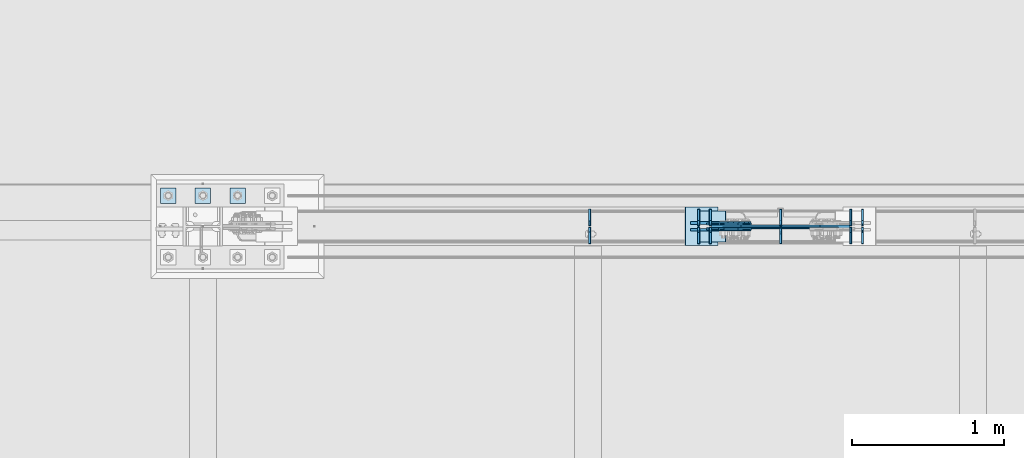
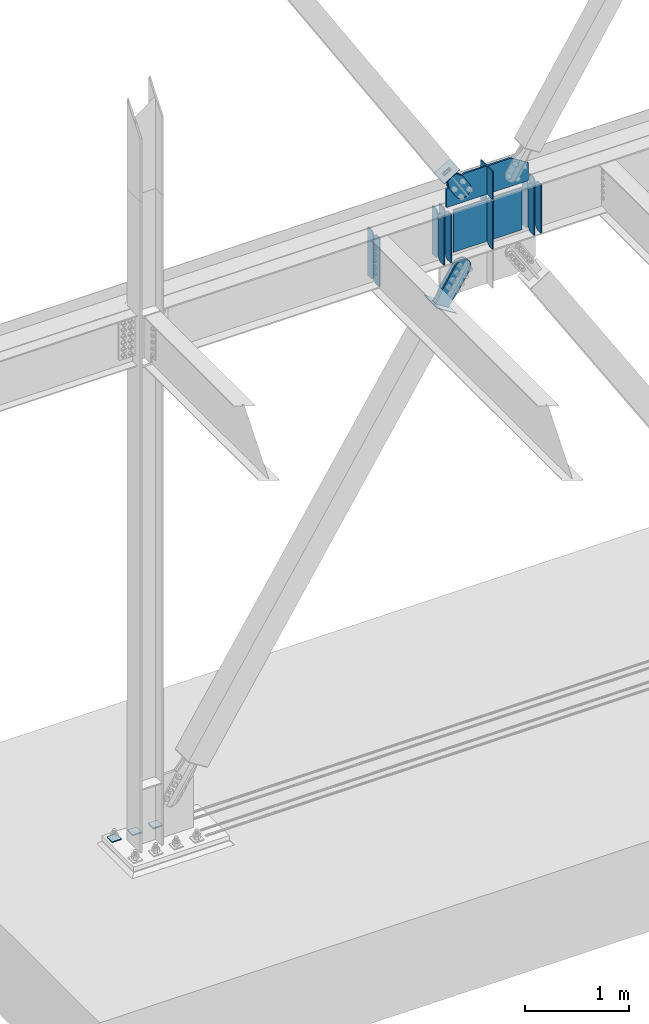
# One storey, part 3521 of 3843: 25 plates, 8 elements without a shape of their own.
"""IFC2X3 building model written with IfcOpenShell, lengths in millimetres."""

from ifc_helpers import new_model, si_unit, frame, origin_with_axes, place, context, subcontext, project, spatial, faceted_brep, material, type_object, element, aggregate, save


model = new_model("IFC2X3")

# Units and contexts
model_context = context("Model", 3, precision=1e-05, world=origin_with_axes())
body_context = subcontext(model_context, "Body", "Model", "MODEL_VIEW")
ifc_project = project(units=[si_unit("LENGTHUNIT", "METRE", prefix="MILLI"), si_unit("AREAUNIT", "SQUARE_METRE"), si_unit("VOLUMEUNIT", "CUBIC_METRE"), si_unit("MASSUNIT", "GRAM", prefix="KILO"), si_unit("TIMEUNIT", "SECOND"), si_unit("PLANEANGLEUNIT", "RADIAN"), si_unit("SOLIDANGLEUNIT", "STERADIAN"), si_unit("THERMODYNAMICTEMPERATUREUNIT", "DEGREE_CELSIUS"), si_unit("LUMINOUSINTENSITYUNIT", "LUMEN")], contexts=[model_context])

# Site, building, storey
site_placement = place(None, origin_with_axes())
site = spatial("IfcSite", under=ifc_project, at=site_placement, CompositionType="ELEMENT")
building_placement = place(site_placement, origin_with_axes())
building = spatial("IfcBuilding", under=site, at=building_placement, Name="Undefined", CompositionType="ELEMENT")
storey_placement = place(building_placement, origin_with_axes())
storey = spatial("IfcBuildingStorey", under=building, at=storey_placement, Name="Undefined", CompositionType="ELEMENT", Elevation=0.0)

# Assembly, plates
assembly_1_placement = place(storey_placement, origin_with_axes())
assembly_1 = element("IfcElementAssembly", 1, at=assembly_1_placement, inside=storey, Name="BEAM", AssemblyPlace="NOTDEFINED", PredefinedType="RIGID_FRAME")
ifc_material_1 = material(Name="STEEL/A572-50")
plate_type_1 = type_object("IfcPlateType", PredefinedType="NOTDEFINED")
plate_1_placement = place(assembly_1_placement, frame((25411.1125000954, 104564.65625, 35848.925), z_axis=(0.0, 0.0, 1.0), x_axis=(0.0, 1.0, 0.0)))
plate_1 = element("IfcPlate", 2, at=plate_1_placement, type_object=plate_type_1, material=ifc_material_1, Name="PLATE", context=body_context, shape_type="Brep", body=[
    faceted_brep([(0.0, -6.35000000000582, 31.75), (0.0, -6.34999999999854, 539.75), (0.0, 6.34999999999854, 539.75), (0.0, 6.35000000000582, 31.75), (31.75, -6.34999999999854, 571.5), (31.75, 6.34999999999854, 571.5), (108.743750000009, -6.34999999999854, 571.5), (108.743750000009, 6.34999999999854, 571.5), (108.743750000009, -6.34999999999854, 0.0), (108.743750000009, 6.34999999999854, 0.0), (31.75, -6.35000000000582, 0.0), (31.75, 6.35000000000582, 0.0)], [[[0, 1, 2, 3]], [[1, 4, 5, 2]], [[4, 6, 7, 5]], [[6, 8, 9, 7]], [[8, 10, 11, 9]], [[10, 0, 3, 11]], [[5, 7, 9, 11, 3, 2]], [[10, 8, 6, 4, 1, 0]]]),
])
plate_type_2 = type_object("IfcPlateType", PredefinedType="NOTDEFINED")
plate_2_placement = place(assembly_1_placement, frame((25411.1125000954, 104553.54375, 35848.925), z_axis=(0.0, 0.0, 1.0), x_axis=(0.0, -1.0, 0.0)))
plate_2 = element("IfcPlate", 3, at=plate_2_placement, type_object=plate_type_2, material=ifc_material_1, Name="PLATE", context=body_context, shape_type="Brep", body=[
    faceted_brep([(0.0, -6.35000000000582, 31.75), (0.0, -6.34999999999854, 539.75), (0.0, 6.34999999999854, 539.75), (0.0, 6.35000000000582, 31.75), (31.75, -6.34999999999854, 571.5), (31.75, 6.34999999999854, 571.5), (107.950000000012, -6.34999999999854, 571.5), (107.950000000012, 6.34999999999854, 571.5), (107.950000000012, -6.34999999999854, 0.0), (107.950000000012, 6.34999999999854, 0.0), (31.75, -6.35000000000582, 0.0), (31.75, 6.35000000000582, 0.0)], [[[0, 1, 2, 3]], [[1, 4, 5, 2]], [[4, 6, 7, 5]], [[6, 8, 9, 7]], [[8, 10, 11, 9]], [[10, 0, 3, 11]], [[5, 7, 9, 11, 3, 2]], [[10, 8, 6, 4, 1, 0]]]),
])
plate_type_3 = type_object("IfcPlateType", PredefinedType="NOTDEFINED")
plate_3_placement = place(assembly_1_placement, frame((26129.8144416841, 104564.65625, 35848.925), z_axis=(0.0, 1.0, 0.0), x_axis=(0.0, 0.0, 1.0)))
plate_3 = element("IfcPlate", 4, at=plate_3_placement, type_object=plate_type_3, material=ifc_material_1, Name="CB_BEAM", context=body_context, shape_type="Brep", body=[
    faceted_brep([(0.0, -6.34999999999854, 33.3375015258789), (0.0, -6.34999999999854, 108.743749999994), (0.0, 6.34999999999854, 108.743749999994), (0.0, 6.34999999999854, 33.3375015258789), (571.5, -6.34999999999854, 108.743749999994), (571.5, 6.34999999999854, 108.743749999994), (571.5, -6.34999999999854, 33.3375015258789), (571.5, 6.34999999999854, 33.3375015258789), (538.162498474121, -6.34999999999854, 0.0), (538.162498474121, 6.34999999999854, 0.0), (33.3375015258789, -6.34999999999854, 0.0), (33.3375015258789, 6.34999999999854, 0.0)], [[[0, 1, 2, 3]], [[1, 4, 5, 2]], [[4, 6, 7, 5]], [[6, 8, 9, 7]], [[8, 10, 11, 9]], [[10, 0, 3, 11]], [[5, 7, 9, 11, 3, 2]], [[10, 8, 6, 4, 1, 0]]]),
])
plate_4_placement = place(assembly_1_placement, frame((26129.8144416841, 104553.54375, 35848.925), z_axis=(0.0, -1.0, 0.0), x_axis=(0.0, 0.0, 1.0)))
plate_4 = element("IfcPlate", 5, at=plate_4_placement, type_object=plate_type_3, material=ifc_material_1, Name="CB_BEAM", context=body_context, shape_type="Brep", body=[
    faceted_brep([(0.0, -6.34999999999854, 33.3375015258789), (0.0, -6.34999999999854, 108.743749999994), (0.0, 6.34999999999854, 108.743749999994), (0.0, 6.34999999999854, 33.3375015258789), (571.5, -6.34999999999854, 108.743749999994), (571.5, 6.34999999999854, 108.743749999994), (571.5, -6.34999999999854, 33.3375015258789), (571.5, 6.34999999999854, 33.3375015258789), (538.162498474121, -6.34999999999854, 0.0), (538.162498474121, 6.34999999999854, 0.0), (33.3375015258789, -6.34999999999854, 0.0), (33.3375015258789, 6.34999999999854, 0.0)], [[[0, 1, 2, 3]], [[1, 4, 5, 2]], [[4, 6, 7, 5]], [[6, 8, 9, 7]], [[8, 10, 11, 9]], [[10, 0, 3, 11]], [[5, 7, 9, 11, 3, 2]], [[10, 8, 6, 4, 1, 0]]]),
])
plate_5_placement = place(assembly_1_placement, frame((26207.1322814053, 104564.65625, 35848.925), z_axis=(0.0, 1.0, 0.0), x_axis=(0.0, 0.0, 1.0)))
plate_5 = element("IfcPlate", 6, at=plate_5_placement, type_object=plate_type_3, material=ifc_material_1, Name="CB_BEAM", context=body_context, shape_type="Brep", body=[
    faceted_brep([(0.0, -6.34999999999854, 33.3375015258789), (0.0, -6.34999999999854, 108.743749999994), (0.0, 6.34999999999854, 108.743749999994), (0.0, 6.34999999999854, 33.3375015258789), (571.5, -6.34999999999854, 108.743749999994), (571.5, 6.34999999999854, 108.743749999994), (571.5, -6.34999999999854, 33.3375015258789), (571.5, 6.34999999999854, 33.3375015258789), (538.162498474121, -6.34999999999854, 0.0), (538.162498474121, 6.34999999999854, 0.0), (33.3375015258789, -6.34999999999854, 0.0), (33.3375015258789, 6.34999999999854, 0.0)], [[[0, 1, 2, 3]], [[1, 4, 5, 2]], [[4, 6, 7, 5]], [[6, 8, 9, 7]], [[8, 10, 11, 9]], [[10, 0, 3, 11]], [[5, 7, 9, 11, 3, 2]], [[10, 8, 6, 4, 1, 0]]]),
])
plate_6_placement = place(assembly_1_placement, frame((26207.1322814053, 104553.54375, 35848.925), z_axis=(0.0, -1.0, 0.0), x_axis=(0.0, 0.0, 1.0)))
plate_6 = element("IfcPlate", 7, at=plate_6_placement, type_object=plate_type_3, material=ifc_material_1, Name="CB_BEAM", context=body_context, shape_type="Brep", body=[
    faceted_brep([(0.0, -6.34999999999854, 33.3375015258789), (0.0, -6.34999999999854, 108.743749999994), (0.0, 6.34999999999854, 108.743749999994), (0.0, 6.34999999999854, 33.3375015258789), (571.5, -6.34999999999854, 108.743749999994), (571.5, 6.34999999999854, 108.743749999994), (571.5, -6.34999999999854, 33.3375015258789), (571.5, 6.34999999999854, 33.3375015258789), (538.162498474121, -6.34999999999854, 0.0), (538.162498474121, 6.34999999999854, 0.0), (33.3375015258789, -6.34999999999854, 0.0), (33.3375015258789, 6.34999999999854, 0.0)], [[[0, 1, 2, 3]], [[1, 4, 5, 2]], [[4, 6, 7, 5]], [[6, 8, 9, 7]], [[8, 10, 11, 9]], [[10, 0, 3, 11]], [[5, 7, 9, 11, 3, 2]], [[10, 8, 6, 4, 1, 0]]]),
])
plate_7_placement = place(assembly_1_placement, frame((27210.1855583159, 104564.65625, 35848.925), z_axis=(0.0, 1.0, 0.0), x_axis=(0.0, 0.0, 1.0)))
plate_7 = element("IfcPlate", 8, at=plate_7_placement, type_object=plate_type_3, material=ifc_material_1, Name="CB_BEAM", context=body_context, shape_type="Brep", body=[
    faceted_brep([(0.0, -6.34999999999854, 33.3375015258789), (0.0, -6.34999999999854, 108.743749999994), (0.0, 6.34999999999854, 108.743749999994), (0.0, 6.34999999999854, 33.3375015258789), (571.5, -6.34999999999854, 108.743749999994), (571.5, 6.34999999999854, 108.743749999994), (571.5, -6.34999999999854, 33.3375015258789), (571.5, 6.34999999999854, 33.3375015258789), (538.162498474121, -6.34999999999854, 0.0), (538.162498474121, 6.34999999999854, 0.0), (33.3375015258789, -6.34999999999854, 0.0), (33.3375015258789, 6.34999999999854, 0.0)], [[[0, 1, 2, 3]], [[1, 4, 5, 2]], [[4, 6, 7, 5]], [[6, 8, 9, 7]], [[8, 10, 11, 9]], [[10, 0, 3, 11]], [[5, 7, 9, 11, 3, 2]], [[10, 8, 6, 4, 1, 0]]]),
])
plate_8_placement = place(assembly_1_placement, frame((27210.1855583159, 104553.54375, 35848.925), z_axis=(0.0, -1.0, 0.0), x_axis=(0.0, 0.0, 1.0)))
plate_8 = element("IfcPlate", 9, at=plate_8_placement, type_object=plate_type_3, material=ifc_material_1, Name="CB_BEAM", context=body_context, shape_type="Brep", body=[
    faceted_brep([(0.0, -6.34999999999854, 33.3375015258789), (0.0, -6.34999999999854, 108.743749999994), (0.0, 6.34999999999854, 108.743749999994), (0.0, 6.34999999999854, 33.3375015258789), (571.5, -6.34999999999854, 108.743749999994), (571.5, 6.34999999999854, 108.743749999994), (571.5, -6.34999999999854, 33.3375015258789), (571.5, 6.34999999999854, 33.3375015258789), (538.162498474121, -6.34999999999854, 0.0), (538.162498474121, 6.34999999999854, 0.0), (33.3375015258789, -6.34999999999854, 0.0), (33.3375015258789, 6.34999999999854, 0.0)], [[[0, 1, 2, 3]], [[1, 4, 5, 2]], [[4, 6, 7, 5]], [[6, 8, 9, 7]], [[8, 10, 11, 9]], [[10, 0, 3, 11]], [[5, 7, 9, 11, 3, 2]], [[10, 8, 6, 4, 1, 0]]]),
])
plate_9_placement = place(assembly_1_placement, frame((27132.8677085345, 104564.65625, 35848.925), z_axis=(0.0, 1.0, 0.0), x_axis=(0.0, 0.0, 1.0)))
plate_9 = element("IfcPlate", 10, at=plate_9_placement, type_object=plate_type_3, material=ifc_material_1, Name="CB_BEAM", context=body_context, shape_type="Brep", body=[
    faceted_brep([(0.0, -6.34999999999854, 33.3375015258789), (0.0, -6.34999999999854, 108.743749999994), (0.0, 6.34999999999854, 108.743749999994), (0.0, 6.34999999999854, 33.3375015258789), (571.5, -6.34999999999854, 108.743749999994), (571.5, 6.34999999999854, 108.743749999994), (571.5, -6.34999999999854, 33.3375015258789), (571.5, 6.34999999999854, 33.3375015258789), (538.162498474121, -6.34999999999854, 0.0), (538.162498474121, 6.34999999999854, 0.0), (33.3375015258789, -6.34999999999854, 0.0), (33.3375015258789, 6.34999999999854, 0.0)], [[[0, 1, 2, 3]], [[1, 4, 5, 2]], [[4, 6, 7, 5]], [[6, 8, 9, 7]], [[8, 10, 11, 9]], [[10, 0, 3, 11]], [[5, 7, 9, 11, 3, 2]], [[10, 8, 6, 4, 1, 0]]]),
])
plate_10_placement = place(assembly_1_placement, frame((27132.8677085345, 104553.54375, 35848.925), z_axis=(0.0, -1.0, 0.0), x_axis=(0.0, 0.0, 1.0)))
plate_10 = element("IfcPlate", 11, at=plate_10_placement, type_object=plate_type_3, material=ifc_material_1, Name="CB_BEAM", context=body_context, shape_type="Brep", body=[
    faceted_brep([(0.0, -6.34999999999854, 33.3375015258789), (0.0, -6.34999999999854, 108.743749999994), (0.0, 6.34999999999854, 108.743749999994), (0.0, 6.34999999999854, 33.3375015258789), (571.5, -6.34999999999854, 108.743749999994), (571.5, 6.34999999999854, 108.743749999994), (571.5, -6.34999999999854, 33.3375015258789), (571.5, 6.34999999999854, 33.3375015258789), (538.162498474121, -6.34999999999854, 0.0), (538.162498474121, 6.34999999999854, 0.0), (33.3375015258789, -6.34999999999854, 0.0), (33.3375015258789, 6.34999999999854, 0.0)], [[[0, 1, 2, 3]], [[1, 4, 5, 2]], [[4, 6, 7, 5]], [[6, 8, 9, 7]], [[8, 10, 11, 9]], [[10, 0, 3, 11]], [[5, 7, 9, 11, 3, 2]], [[10, 8, 6, 4, 1, 0]]]),
])
plate_11_placement = place(assembly_1_placement, frame((26669.9999949699, 104564.65625, 35848.925), z_axis=(0.0, 1.0, 0.0), x_axis=(0.0, 0.0, 1.0)))
plate_11 = element("IfcPlate", 12, at=plate_11_placement, type_object=plate_type_3, material=ifc_material_1, Name="CB_BEAM", context=body_context, shape_type="Brep", body=[
    faceted_brep([(0.0, -6.34999999999854, 33.3375015258789), (0.0, -6.34999999999854, 108.743749999994), (0.0, 6.34999999999854, 108.743749999994), (0.0, 6.34999999999854, 33.3375015258789), (571.5, -6.34999999999854, 108.743749999994), (571.5, 6.34999999999854, 108.743749999994), (571.5, -6.34999999999854, 33.3375015258789), (571.5, 6.34999999999854, 33.3375015258789), (538.162498474121, -6.34999999999854, 0.0), (538.162498474121, 6.34999999999854, 0.0), (33.3375015258789, -6.34999999999854, 0.0), (33.3375015258789, 6.34999999999854, 0.0)], [[[0, 1, 2, 3]], [[1, 4, 5, 2]], [[4, 6, 7, 5]], [[6, 8, 9, 7]], [[8, 10, 11, 9]], [[10, 0, 3, 11]], [[5, 7, 9, 11, 3, 2]], [[10, 8, 6, 4, 1, 0]]]),
])
plate_type_4 = type_object("IfcPlateType", PredefinedType="NOTDEFINED")
plate_12_placement = place(assembly_1_placement, frame((26288.9999949699, 104548.78125, 36388.6749984741), z_axis=(1.0, 0.0, 0.0), x_axis=(0.0, 0.0, -1.0)))
plate_12 = element("IfcPlate", 13, at=plate_12_placement, type_object=plate_type_4, material=ifc_material_1, Name="PLATE", context=body_context, shape_type="Brep", body=[
    faceted_brep([(502.500735361689, -4.76249999999709, 0.0), (507.999996948238, 4.76249999999709, 0.0), (507.99999694826, 4.76249999999709, 762.000000000007), (502.500735361689, -4.76249999999709, 762.000000000007), (5.49926154989225, -4.76249999999709, 762.000000000007), (5.49926154989225, -4.76249999999709, 0.0), (0.0, 4.76249999999709, 0.0), (7.27595761418343e-12, 4.76249999999709, 762.000000000007)], [[[0, 1, 2, 3]], [[0, 3, 4, 5]], [[1, 0, 5, 6]], [[2, 1, 6, 7]], [[3, 2, 7, 4]], [[6, 5, 4, 7]]]),
])
plate_type_5 = type_object("IfcPlateType", PredefinedType="NOTDEFINED")
plate_13_placement = place(assembly_1_placement, frame((26669.9999949699, 104568.625, 36436.3), z_axis=(0.0, 1.0, 0.0), x_axis=(0.0, 0.0, 1.0)))
plate_13 = element("IfcPlate", 14, at=plate_13_placement, type_object=plate_type_5, material=ifc_material_1, Name="CB", context=body_context, shape_type="Brep", body=[
    faceted_brep([(0.0, -6.34999999999854, 19.0499992370605), (0.0, -6.34999999999854, 104.775000000009), (0.0, 6.34999999999854, 104.775000000009), (0.0, 6.34999999999854, 19.0499992370605), (333.366558250316, -6.34999999999854, 104.775000000009), (333.366558250316, 6.34999999999854, 104.775000000009), (333.366558250316, -6.34999999999854, 0.0), (333.366558250316, 6.34999999999854, 0.0), (19.0499992370605, -6.34999999999854, 0.0), (19.0499992370605, 6.34999999999854, 0.0)], [[[0, 1, 2, 3]], [[1, 4, 5, 2]], [[4, 6, 7, 5]], [[6, 8, 9, 7]], [[8, 0, 3, 9]], [[5, 7, 9, 3, 2]], [[8, 6, 4, 1, 0]]]),
])
plate_14_placement = place(assembly_1_placement, frame((26669.9999949699, 104549.575, 36436.3), z_axis=(0.0, -1.0, 0.0), x_axis=(0.0, 0.0, 1.0)))
plate_14 = element("IfcPlate", 15, at=plate_14_placement, type_object=plate_type_5, material=ifc_material_1, Name="CB", context=body_context, shape_type="Brep", body=[
    faceted_brep([(0.0, -6.34999999999854, 19.0499992370605), (0.0, -6.34999999999854, 104.775000000009), (0.0, 6.34999999999854, 104.775000000009), (0.0, 6.34999999999854, 19.0499992370605), (333.366558250316, -6.34999999999854, 104.775000000009), (333.366558250316, 6.34999999999854, 104.775000000009), (333.366558250316, -6.34999999999854, 0.0), (333.366558250316, 6.34999999999854, 0.0), (19.0499992370605, -6.34999999999854, 0.0), (19.0499992370605, 6.34999999999854, 0.0)], [[[0, 1, 2, 3]], [[1, 4, 5, 2]], [[4, 6, 7, 5]], [[6, 8, 9, 7]], [[8, 0, 3, 9]], [[5, 7, 9, 3, 2]], [[8, 6, 4, 1, 0]]]),
])
plate_type_6 = type_object("IfcPlateType", PredefinedType="NOTDEFINED")
plate_15_placement = place(assembly_1_placement, frame((26213.4822814053, 104559.1, 36436.3), z_axis=(1.0, 0.0, 0.0), x_axis=(0.0, 0.0, 1.0)))
plate_15 = element("IfcPlate", 16, at=plate_15_placement, type_object=plate_type_6, material=ifc_material_1, Name="CB", context=body_context, shape_type="Brep", body=[
    faceted_brep([(0.0, -9.52500000000146, 0.0), (-1.45519152283669e-11, -9.52499999997963, 913.035427129151), (2.91038304567337e-11, 9.52500000000873, 913.035427129151), (0.0, 9.52500000000146, 0.0), (210.595034109829, -9.52500000041618, 913.035427129151), (210.595034109872, 9.52499999957217, 913.035427129151), (333.366558250302, -9.52500000066357, 716.447524436167), (333.366558250345, 9.52499999933934, 716.447524436167), (333.366558250302, -9.52500000066357, 462.867713564574), (333.366558250345, 9.52499999933934, 462.867713564574), (333.366558250302, -9.52500000066357, 196.587902692983), (333.366558250345, 9.52499999933934, 196.587902692983), (210.595034109829, -9.52500000041618, 0.0), (210.595034109872, 9.52499999957217, 0.0)], [[[0, 1, 2, 3]], [[1, 4, 5, 2]], [[4, 6, 7, 5]], [[6, 8, 9, 7]], [[8, 10, 11, 9]], [[10, 12, 13, 11]], [[12, 0, 3, 13]], [[5, 7, 9, 11, 13, 3, 2]], [[12, 10, 8, 6, 4, 1, 0]]]),
])

# Assembly, plate
assembly_2_placement = place(storey_placement, origin_with_axes())
assembly_2 = element("IfcElementAssembly", 17, at=assembly_2_placement, inside=storey, AssemblyPlace="NOTDEFINED", PredefinedType="RIGID_FRAME")
ifc_material_2 = material(Name="STEEL/A36")
plate_type_7 = type_object("IfcPlateType", PredefinedType="NOTDEFINED")
plate_16_placement = place(assembly_2_placement, frame((26259.8051907505, 104574.975, 36877.961937569), z_axis=(-0.848184242014813, 0.0, -0.529701323009256), x_axis=(0.529701323009257, 0.0, -0.848184242014813)))
plate_16 = element("IfcPlate", 18, at=plate_16_placement, type_object=plate_type_7, material=ifc_material_2, context=body_context, shape_type="Brep", body=[
    faceted_brep([(0.0, -6.3499999046162, 0.0), (2.18278728425503e-10, -6.35000000000582, 91.5986124321353), (2.18278728425503e-10, 6.35000000000582, 91.5986124321353), (7.27595761418343e-12, 6.3499999046162, 0.0), (69.8499999987471, -6.35000000000582, 91.598612432037), (69.8499999987471, 6.35000000000582, 91.598612432037), (171.44999999673, -6.35000000000582, 136.286806214401), (171.44999999673, 6.35000000000582, 136.286806214401), (316.534985839971, -6.35000000000582, 136.286806214212), (316.534985839971, 6.35000000000582, 136.286806214212), (351.163054093879, -6.35000000000582, 129.398855179952), (351.163054093879, 6.35000000000582, 129.398855179952), (380.51931286032, -6.35000000000582, 109.783630182814), (380.51931286032, 6.35000000000582, 109.783630182814), (400.134537857251, -6.35000000000582, 80.42737141615), (400.134537857251, 6.35000000000582, 80.42737141615), (407.022488891344, -6.35000000000582, 45.7993092690485), (407.022488891344, 6.35000000000582, 45.7993092690485), (400.134537857084, -6.35000000000582, 11.1712410149557), (400.134537857084, 6.35000000000582, 11.1712410149557), (380.519312860015, -6.35000000000582, -18.1850177516608), (380.519312860015, 6.35000000000582, -18.1850177516608), (351.163054093486, -6.35000000000582, -37.8002427487263), (351.163054093486, 6.35000000000582, -37.8002427487263), (316.534988893036, -6.35000000000582, -44.6881937828948), (316.534988893036, 6.35000000000582, -44.6881937828948), (171.449999996279, -6.35000000000582, -44.6881937827056), (171.449999996279, 6.35000000000582, -44.6881937827056), (69.8499999985434, -6.35000000000582, -8.73114913702011e-11), (69.8499999985434, 6.35000000000582, -8.73114913702011e-11)], [[[0, 1, 2, 3]], [[1, 4, 5, 2]], [[4, 6, 7, 5]], [[6, 8, 9, 7]], [[8, 10, 11, 9]], [[10, 12, 13, 11]], [[12, 14, 15, 13]], [[14, 16, 17, 15]], [[16, 18, 19, 17]], [[18, 20, 21, 19]], [[20, 22, 23, 21]], [[22, 24, 25, 23]], [[24, 26, 27, 25]], [[26, 28, 29, 27]], [[28, 0, 3, 29]], [[5, 7, 9, 11, 13, 15, 17, 19, 21, 23, 25, 27, 29, 3, 2]], [[28, 26, 24, 22, 20, 18, 16, 14, 12, 10, 8, 6, 4, 1, 0]]]),
])
aggregate(assembly_2, [plate_16])

assembly_3_placement = place(storey_placement, origin_with_axes())
assembly_3 = element("IfcElementAssembly", 19, at=assembly_3_placement, inside=storey, AssemblyPlace="NOTDEFINED", PredefinedType="RIGID_FRAME")
plate_17_placement = place(assembly_3_placement, frame((26259.8051907505, 104543.225, 36877.961937569), z_axis=(-0.848184242014813, 0.0, -0.529701323009256), x_axis=(0.529701323009257, 0.0, -0.848184242014813)))
plate_17 = element("IfcPlate", 20, at=plate_17_placement, type_object=plate_type_7, material=ifc_material_2, context=body_context, shape_type="Brep", body=[
    faceted_brep([(0.0, -6.3499999046162, 0.0), (2.18278728425503e-10, -6.35000000000582, 91.5986124321353), (2.18278728425503e-10, 6.35000000000582, 91.5986124321353), (7.27595761418343e-12, 6.3499999046162, 0.0), (69.8499999987471, -6.35000000000582, 91.598612432037), (69.8499999987471, 6.35000000000582, 91.598612432037), (171.44999999673, -6.35000000000582, 136.286806214401), (171.44999999673, 6.35000000000582, 136.286806214401), (316.534985839971, -6.35000000000582, 136.286806214212), (316.534985839971, 6.35000000000582, 136.286806214212), (351.163054093879, -6.35000000000582, 129.398855179952), (351.163054093879, 6.35000000000582, 129.398855179952), (380.51931286032, -6.35000000000582, 109.783630182814), (380.51931286032, 6.35000000000582, 109.783630182814), (400.134537857251, -6.35000000000582, 80.42737141615), (400.134537857251, 6.35000000000582, 80.42737141615), (407.022488891344, -6.35000000000582, 45.7993092690485), (407.022488891344, 6.35000000000582, 45.7993092690485), (400.134537857084, -6.35000000000582, 11.1712410149557), (400.134537857084, 6.35000000000582, 11.1712410149557), (380.519312860015, -6.35000000000582, -18.1850177516608), (380.519312860015, 6.35000000000582, -18.1850177516608), (351.163054093486, -6.35000000000582, -37.8002427487263), (351.163054093486, 6.35000000000582, -37.8002427487263), (316.534988893036, -6.35000000000582, -44.6881937828948), (316.534988893036, 6.35000000000582, -44.6881937828948), (171.449999996279, -6.35000000000582, -44.6881937827056), (171.449999996279, 6.35000000000582, -44.6881937827056), (69.8499999985434, -6.35000000000582, -8.73114913702011e-11), (69.8499999985434, 6.35000000000582, -8.73114913702011e-11)], [[[0, 1, 2, 3]], [[1, 4, 5, 2]], [[4, 6, 7, 5]], [[6, 8, 9, 7]], [[8, 10, 11, 9]], [[10, 12, 13, 11]], [[12, 14, 15, 13]], [[14, 16, 17, 15]], [[16, 18, 19, 17]], [[18, 20, 21, 19]], [[20, 22, 23, 21]], [[22, 24, 25, 23]], [[24, 26, 27, 25]], [[26, 28, 29, 27]], [[28, 0, 3, 29]], [[5, 7, 9, 11, 13, 15, 17, 19, 21, 23, 25, 27, 29, 3, 2]], [[28, 26, 24, 22, 20, 18, 16, 14, 12, 10, 8, 6, 4, 1, 0]]]),
])
aggregate(assembly_3, [plate_17])

assembly_4_placement = place(storey_placement, origin_with_axes())
assembly_4 = element("IfcElementAssembly", 21, at=assembly_4_placement, inside=storey, Name="Plate", AssemblyPlace="NOTDEFINED", PredefinedType="RIGID_FRAME")
plate_type_8 = type_object("IfcPlateType", PredefinedType="NOTDEFINED")
plate_18_placement = place(assembly_4_placement, frame((26136.4652236342, 104660.7, 36797.1913450867), z_axis=(0.848184242014813, 0.0, 0.529701323009256), x_axis=(0.0, -1.0, 0.0)))
plate_18 = element("IfcPlate", 22, at=plate_18_placement, type_object=plate_type_8, material=ifc_material_2, Name="Plate", context=body_context, shape_type="Brep", body=[
    faceted_brep([(0.0, -3.17499999999927, 0.0), (0.0, -3.17500000043947, 203.200000001736), (0.0, 3.1749999995518, 203.200000001743), (0.0, 3.17499999999927, 0.0), (203.200000000012, -3.17500000043947, 203.200000001736), (203.200000000012, 3.1749999995518, 203.200000001743), (203.199996948242, -3.17499999999927, 0.0), (203.199996948242, 3.17499999999927, 0.0)], [[[0, 1, 2, 3]], [[1, 4, 5, 2]], [[4, 6, 7, 5]], [[6, 0, 3, 7]], [[5, 7, 3, 2]], [[6, 4, 1, 0]]]),
])
aggregate(assembly_4, [plate_18])

# Plate
plate_type_9 = type_object("IfcPlateType", PredefinedType="NOTDEFINED")
plate_19_placement = place(assembly_1_placement, frame((26669.9999949699, 104544.01875, 35848.925), z_axis=(0.0, -1.0, 0.0), x_axis=(0.0, 0.0, 1.0)))
plate_19 = element("IfcPlate", 23, at=plate_19_placement, type_object=plate_type_9, material=ifc_material_1, Name="CB_BEAM", context=body_context, shape_type="Brep", body=[
    faceted_brep([(0.0, -6.34999999999854, 33.3375015258789), (0.0, -6.34999999999854, 99.2187500000146), (0.0, 6.34999999999854, 99.2187500000146), (0.0, 6.34999999999854, 33.3375015258789), (571.5, -6.34999999999854, 99.2187500000146), (571.5, 6.34999999999854, 99.2187500000146), (571.5, -6.34999999999854, 33.3375015258789), (571.5, 6.34999999999854, 33.3375015258789), (538.162498474121, -6.34999999999854, 0.0), (538.162498474121, 6.34999999999854, 0.0), (33.3375015258789, -6.34999999999854, 0.0), (33.3375015258789, 6.34999999999854, 0.0)], [[[0, 1, 2, 3]], [[1, 4, 5, 2]], [[4, 6, 7, 5]], [[6, 8, 9, 7]], [[8, 10, 11, 9]], [[10, 0, 3, 11]], [[5, 7, 9, 11, 3, 2]], [[10, 8, 6, 4, 1, 0]]]),
])

aggregate(assembly_1, [plate_1, plate_2, plate_3, plate_4, plate_5, plate_6, plate_7, plate_8, plate_9, plate_10, plate_12, plate_11, plate_19, plate_13, plate_14, plate_15])

# Assembly, plates
assembly_5_placement = place(storey_placement, origin_with_axes())
assembly_5 = element("IfcElementAssembly", 24, at=assembly_5_placement, inside=storey, Name="TEMPLATE", AssemblyPlace="NOTDEFINED", PredefinedType="RIGID_FRAME")
plate_type_10 = type_object("IfcPlateType", PredefinedType="NOTDEFINED")
plate_20_placement = place(assembly_5_placement, frame((23037.8, 104813.1, 30130.75), z_axis=(0.0, -1.0, 0.0), x_axis=(1.0, 0.0, 0.0)))
plate_20 = element("IfcPlate", 25, at=plate_20_placement, type_object=plate_type_10, material=ifc_material_1, Name="Washer Plate", context=body_context, shape_type="Brep", body=[
    faceted_brep([(0.0, -6.3499999046162, 0.0), (-1.67347025126219e-10, -6.35000000000582, 101.600000000151), (-1.67347025126219e-10, 6.35000000000582, 101.600000000151), (7.27595761418343e-12, 6.3499999046162, 0.0), (101.599998474121, -6.34999999999854, 101.599998474121), (101.599998474121, 6.34999999999854, 101.599998474121), (101.6, -6.34999999999854, 0.0), (101.6, 6.34999999999854, 0.0)], [[[0, 1, 2, 3]], [[1, 4, 5, 2]], [[4, 6, 7, 5]], [[6, 0, 3, 7]], [[5, 7, 3, 2]], [[6, 4, 1, 0]]]),
])
plate_21_placement = place(assembly_5_placement, frame((22809.2, 104813.1, 30130.75), z_axis=(0.0, -1.0, 0.0), x_axis=(1.0, 0.0, 0.0)))
plate_21 = element("IfcPlate", 26, at=plate_21_placement, type_object=plate_type_10, material=ifc_material_1, Name="Washer Plate", context=body_context, shape_type="Brep", body=[
    faceted_brep([(0.0, -6.3499999046162, 0.0), (-1.67347025126219e-10, -6.35000000000582, 101.600000000151), (-1.67347025126219e-10, 6.35000000000582, 101.600000000151), (7.27595761418343e-12, 6.3499999046162, 0.0), (101.599998474121, -6.34999999999854, 101.599998474121), (101.599998474121, 6.34999999999854, 101.599998474121), (101.6, -6.34999999999854, 0.0), (101.6, 6.34999999999854, 0.0)], [[[0, 1, 2, 3]], [[1, 4, 5, 2]], [[4, 6, 7, 5]], [[6, 0, 3, 7]], [[5, 7, 3, 2]], [[6, 4, 1, 0]]]),
])
plate_22_placement = place(assembly_5_placement, frame((22580.6, 104813.1, 30130.75), z_axis=(0.0, -1.0, 0.0), x_axis=(1.0, 0.0, 0.0)))
plate_22 = element("IfcPlate", 27, at=plate_22_placement, type_object=plate_type_10, material=ifc_material_1, Name="Washer Plate", context=body_context, shape_type="Brep", body=[
    faceted_brep([(0.0, -6.3499999046162, 0.0), (-1.67347025126219e-10, -6.35000000000582, 101.600000000151), (-1.67347025126219e-10, 6.35000000000582, 101.600000000151), (7.27595761418343e-12, 6.3499999046162, 0.0), (101.599998474121, -6.34999999999854, 101.599998474121), (101.599998474121, 6.34999999999854, 101.599998474121), (101.6, -6.34999999999854, 0.0), (101.6, 6.34999999999854, 0.0)], [[[0, 1, 2, 3]], [[1, 4, 5, 2]], [[4, 6, 7, 5]], [[6, 0, 3, 7]], [[5, 7, 3, 2]], [[6, 4, 1, 0]]]),
])
aggregate(assembly_5, [plate_20, plate_21, plate_22])

# Assembly, plate
assembly_6_placement = place(storey_placement, origin_with_axes())
assembly_6 = element("IfcElementAssembly", 28, at=assembly_6_placement, inside=storey, AssemblyPlace="NOTDEFINED", PredefinedType="RIGID_FRAME")
plate_type_11 = type_object("IfcPlateType", PredefinedType="NOTDEFINED")
plate_23_placement = place(assembly_6_placement, frame((26218.9893134742, 104581.325, 35265.3589672091), z_axis=(-0.844597156660866, 0.0, 0.535402318785024), x_axis=(0.535402318785024, 0.0, 0.844597156660866)))
plate_23 = element("IfcPlate", 29, at=plate_23_placement, type_object=plate_type_11, material=ifc_material_2, context=body_context, shape_type="Brep", body=[
    faceted_brep([(0.0, -9.52500000000146, 0.0), (-2.16823536902666e-09, -9.52499999999418, 169.022957228546), (-2.16823536902666e-09, 9.52499999999418, 169.022957228546), (0.0, 9.52500000000146, 0.0), (69.8499999974956, -9.52499999999418, 169.02295722875), (69.8499999974956, 9.52499999999418, 169.02295722875), (171.449999996829, -9.52499999999418, 181.348978614493), (171.449999996829, 9.52499999999418, 181.348978614493), (434.579297661258, -9.52499999999418, 181.348978615235), (434.579297661258, 9.52499999999418, 181.348978615235), (471.63740512668, -9.52499999999418, 173.977662728823), (471.63740512668, 9.52499999999418, 173.977662728823), (503.053751663178, -9.52499999999418, 152.985931091971), (503.053751663178, 9.52499999999418, 152.985931091971), (524.045483300536, -9.52499999999418, 121.569584555793), (524.045483300536, 9.52499999999418, 121.569584555793), (531.416799187516, -9.52499999999418, 84.511480142959), (531.416799187516, 9.52499999999418, 84.511480142959), (524.0454833013, -9.52499999999418, 47.4533726770169), (524.0454833013, 9.52499999999418, 47.4533726770169), (503.053751664252, -9.52499999999418, 16.0370261400676), (503.053751664252, 9.52499999999418, 16.0370261400676), (471.63740512763, -9.52499999999418, -4.95470549746824), (471.63740512763, 9.52499999999418, -4.95470549746824), (434.579299189239, -9.52499999999418, -12.3260213842586), (434.579299189239, 9.52499999999418, -12.3260213842586), (171.44999999931, -9.52499999999418, -12.3260213849862), (171.44999999931, 9.52499999999418, -12.3260213849862), (69.8499999979995, -9.52499999999418, -4.00177668780088e-10), (69.8499999979995, 9.52499999999418, -4.00177668780088e-10)], [[[0, 1, 2, 3]], [[1, 4, 5, 2]], [[4, 6, 7, 5]], [[6, 8, 9, 7]], [[8, 10, 11, 9]], [[10, 12, 13, 11]], [[12, 14, 15, 13]], [[14, 16, 17, 15]], [[16, 18, 19, 17]], [[18, 20, 21, 19]], [[20, 22, 23, 21]], [[22, 24, 25, 23]], [[24, 26, 27, 25]], [[26, 28, 29, 27]], [[28, 0, 3, 29]], [[5, 7, 9, 11, 13, 15, 17, 19, 21, 23, 25, 27, 29, 3, 2]], [[28, 26, 24, 22, 20, 18, 16, 14, 12, 10, 8, 6, 4, 1, 0]]]),
])
aggregate(assembly_6, [plate_23])

assembly_7_placement = place(storey_placement, origin_with_axes())
assembly_7 = element("IfcElementAssembly", 30, at=assembly_7_placement, inside=storey, AssemblyPlace="NOTDEFINED", PredefinedType="RIGID_FRAME")
plate_24_placement = place(assembly_7_placement, frame((26218.9893134742, 104536.875, 35265.3589672091), z_axis=(-0.844597156660866, 0.0, 0.535402318785024), x_axis=(0.535402318785024, 0.0, 0.844597156660866)))
plate_24 = element("IfcPlate", 31, at=plate_24_placement, type_object=plate_type_11, material=ifc_material_2, context=body_context, shape_type="Brep", body=[
    faceted_brep([(0.0, -9.52500000000146, 0.0), (-2.16823536902666e-09, -9.52499999999418, 169.022957228546), (-2.16823536902666e-09, 9.52499999999418, 169.022957228546), (0.0, 9.52500000000146, 0.0), (69.8499999974956, -9.52499999999418, 169.02295722875), (69.8499999974956, 9.52499999999418, 169.02295722875), (171.449999996829, -9.52499999999418, 181.348978614493), (171.449999996829, 9.52499999999418, 181.348978614493), (434.579297661258, -9.52499999999418, 181.348978615235), (434.579297661258, 9.52499999999418, 181.348978615235), (471.63740512668, -9.52499999999418, 173.977662728823), (471.63740512668, 9.52499999999418, 173.977662728823), (503.053751663178, -9.52499999999418, 152.985931091971), (503.053751663178, 9.52499999999418, 152.985931091971), (524.045483300536, -9.52499999999418, 121.569584555793), (524.045483300536, 9.52499999999418, 121.569584555793), (531.416799187516, -9.52499999999418, 84.511480142959), (531.416799187516, 9.52499999999418, 84.511480142959), (524.0454833013, -9.52499999999418, 47.4533726770169), (524.0454833013, 9.52499999999418, 47.4533726770169), (503.053751664252, -9.52499999999418, 16.0370261400676), (503.053751664252, 9.52499999999418, 16.0370261400676), (471.63740512763, -9.52499999999418, -4.95470549746824), (471.63740512763, 9.52499999999418, -4.95470549746824), (434.579299189239, -9.52499999999418, -12.3260213842586), (434.579299189239, 9.52499999999418, -12.3260213842586), (171.44999999931, -9.52499999999418, -12.3260213849862), (171.44999999931, 9.52499999999418, -12.3260213849862), (69.8499999979995, -9.52499999999418, -4.00177668780088e-10), (69.8499999979995, 9.52499999999418, -4.00177668780088e-10)], [[[0, 1, 2, 3]], [[1, 4, 5, 2]], [[4, 6, 7, 5]], [[6, 8, 9, 7]], [[8, 10, 11, 9]], [[10, 12, 13, 11]], [[12, 14, 15, 13]], [[14, 16, 17, 15]], [[16, 18, 19, 17]], [[18, 20, 21, 19]], [[20, 22, 23, 21]], [[22, 24, 25, 23]], [[24, 26, 27, 25]], [[26, 28, 29, 27]], [[28, 0, 3, 29]], [[5, 7, 9, 11, 13, 15, 17, 19, 21, 23, 25, 27, 29, 3, 2]], [[28, 26, 24, 22, 20, 18, 16, 14, 12, 10, 8, 6, 4, 1, 0]]]),
])
aggregate(assembly_7, [plate_24])

assembly_8_placement = place(storey_placement, origin_with_axes())
assembly_8 = element("IfcElementAssembly", 32, at=assembly_8_placement, inside=storey, Name="Plate", AssemblyPlace="NOTDEFINED", PredefinedType="RIGID_FRAME")
plate_type_12 = type_object("IfcPlateType", PredefinedType="NOTDEFINED")
plate_25_placement = place(assembly_8_placement, frame((26256.5749002336, 104432.1, 35245.2921102539), z_axis=(-0.844597156660866, 0.0, 0.535402318785024), x_axis=(0.0, 1.0, 0.0)))
plate_25 = element("IfcPlate", 33, at=plate_25_placement, type_object=plate_type_12, material=ifc_material_2, Name="Plate", context=body_context, shape_type="Brep", body=[
    faceted_brep([(0.0, -3.17499999999927, 0.0), (0.0, -3.17499999965185, 254.000000005151), (0.0, 3.17500000035216, 254.000000005166), (0.0, 3.17499999999927, 0.0), (254.0, -3.17499999965185, 254.000000005151), (254.0, 3.17500000035216, 254.000000005166), (254.0, -3.17500000000291, 0.0), (254.0, 3.17499999999927, 1.45519152283669e-11)], [[[0, 1, 2, 3]], [[1, 4, 5, 2]], [[4, 6, 7, 5]], [[6, 0, 3, 7]], [[5, 7, 3, 2]], [[6, 4, 1, 0]]]),
])
aggregate(assembly_8, [plate_25])

save(model, "model.ifc")
